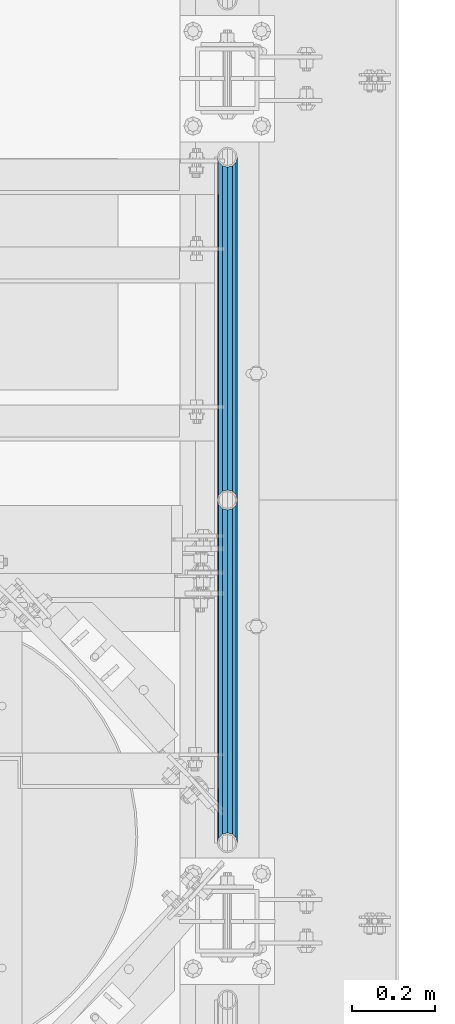
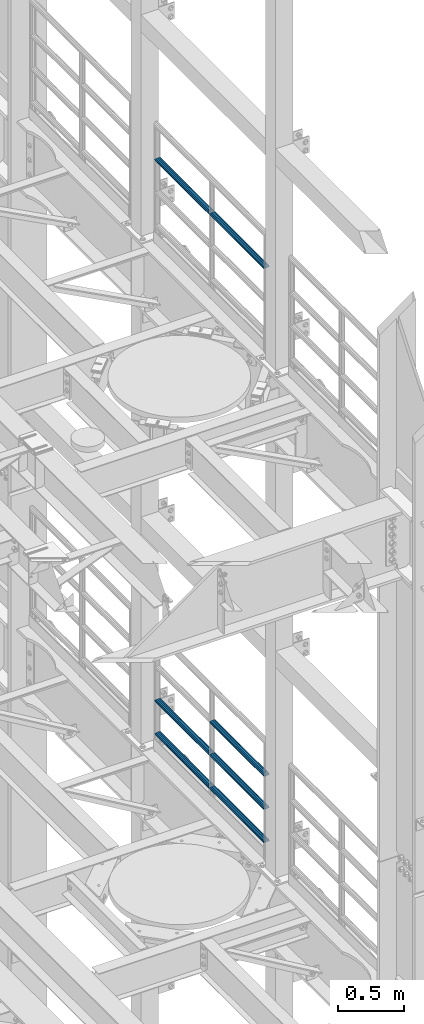
# One storey, part 1279 of 1876: 7 beams, 2 elements without a shape of their own.
"""IFC2X3 building model written with IfcOpenShell, lengths in millimetres."""

from ifc_helpers import new_model, si_unit, frame, origin_with_axes, place, context, subcontext, project, spatial, faceted_brep, material, type_object, element, aggregate, save


model = new_model("IFC2X3")

# Units and contexts
model_context = context("Model", 3, precision=1e-05, world=origin_with_axes())
body_context = subcontext(model_context, "Body", "Model", "MODEL_VIEW")
ifc_project = project(units=[si_unit("LENGTHUNIT", "METRE", prefix="MILLI"), si_unit("AREAUNIT", "SQUARE_METRE"), si_unit("VOLUMEUNIT", "CUBIC_METRE"), si_unit("MASSUNIT", "GRAM", prefix="KILO"), si_unit("TIMEUNIT", "SECOND"), si_unit("PLANEANGLEUNIT", "RADIAN"), si_unit("SOLIDANGLEUNIT", "STERADIAN"), si_unit("THERMODYNAMICTEMPERATUREUNIT", "DEGREE_CELSIUS"), si_unit("LUMINOUSINTENSITYUNIT", "LUMEN")], contexts=[model_context])

# Site, building, storey
site_placement = place(None, origin_with_axes())
site = spatial("IfcSite", under=ifc_project, at=site_placement, CompositionType="ELEMENT")
building_placement = place(site_placement, origin_with_axes())
building = spatial("IfcBuilding", under=site, at=building_placement, Name="Undefined", CompositionType="ELEMENT")
storey_placement = place(building_placement, origin_with_axes())
storey = spatial("IfcBuildingStorey", under=building, at=storey_placement, Name="Undefined", CompositionType="ELEMENT", Elevation=0.0)

# Assembly, beams
assembly_1_placement = place(storey_placement, origin_with_axes())
assembly_1 = element("IfcElementAssembly", 1, at=assembly_1_placement, inside=storey, Name="RAIL", AssemblyPlace="NOTDEFINED", PredefinedType="RIGID_FRAME")
ifc_material = material()
beam_type = type_object("IfcBeamType", Name="PIPE1-1/2SCH40", PredefinedType="NOTDEFINED")
beam_1_placement = place(assembly_1_placement, frame((7620.0, 3745.23, 18754.725), z_axis=(0.0, 0.0, -1.0), x_axis=(0.0, 1.0, 0.0)))
beam_1 = element("IfcBeam", 2, at=beam_1_placement, type_object=beam_type, material=ifc_material, Name="RAIL", ObjectType="PIPE1-1/2SCH40", context=body_context, shape_type="Brep", body=[
    faceted_brep([(0.0, 24.1299999999992, 0.0), (12.0650000000064, 20.8971929933177, -12.0649999999987), (12.0650000000064, 20.8971929933177, 12.0649999999987), (12.0650000000064, -20.8971929933177, 12.0649999999987), (12.0650000000064, -20.8971929933177, -12.0649999999987), (0.0, -24.1299999999992, 0.0), (20.8971929933249, -12.0650000000005, 20.8971929933177), (20.8971929933249, -12.0650000000005, 15.8661214311796), (15.2545715621445, -17.7076214311801, 10.2235000000001), (12.5151929933249, -20.4470000000001, 0.0), (15.2545715621445, -17.7076214311801, -10.2235000000001), (20.8971929933249, -12.0650000000005, -15.8661214311796), (20.8971929933249, -12.0650000000005, -20.8971929933177), (24.1300000000063, 0.0, -20.4470000000001), (24.1300000000063, 0.0, -24.130000000001), (21.3906214311868, -10.2235000000001, -17.7076214311819), (21.3906214311868, 10.2235000000001, -17.7076214311819), (20.8971929933249, 12.0650000000005, -15.8661214311796), (20.8971929933249, 12.0650000000005, -20.8971929933177), (15.2545715621445, 17.7076214311801, -10.2235000000001), (12.5151929933249, 20.4470000000001, 0.0), (15.2545715621445, 17.7076214311801, 10.2235000000001), (20.8971929933249, 12.0650000000005, 15.8661214311796), (20.8971929933249, 12.0650000000005, 20.8971929933177), (21.3906214311868, 10.2235000000001, 17.7076214311819), (24.1300000000064, 0.0, 20.4470000000001), (24.1300000000064, 0.0, 24.130000000001), (21.3906214311868, -10.2235000000001, 17.7076214311819), (826.77, 24.1300000000001, 0.0), (814.705, 20.8971929933186, -12.0649999999987), (805.872807006681, 12.0649999999996, -20.8971929933177), (826.77, -24.1300000000001, 0.0), (814.705, -20.8971929933186, -12.0649999999987), (814.705, -20.8971929933186, 12.0649999999987), (805.872807006681, -12.0649999999996, 20.8971929933177), (805.872807006681, -12.0649999999996, -20.8971929933177), (802.640000000001, 0.0, -24.130000000001), (805.379378568819, 10.2235000000001, -17.7076214311819), (802.640000000001, 0.0, -20.4470000000001), (805.872807006683, 12.0649999999996, -15.8661214311796), (805.872807006683, -12.0649999999996, -15.8661214311796), (805.379378568819, -10.2235000000001, -17.7076214311819), (811.515428437862, -17.7076214311801, -10.2235000000001), (814.254807006682, -20.4470000000001, 0.0), (811.515428437862, -17.7076214311801, 10.2235000000001), (805.872807006683, -12.0649999999996, 15.8661214311796), (805.379378568819, -10.2235000000001, 17.7076214311819), (802.640000000001, 0.0, 20.4470000000001), (802.640000000001, 0.0, 24.130000000001), (805.872807006681, 12.0649999999996, 20.8971929933177), (814.705, 20.8971929933186, 12.0649999999987), (805.872807006683, 12.0649999999996, 15.8661214311796), (811.515428437862, 17.7076214311801, 10.2235000000001), (814.254807006682, 20.4470000000001, 0.0), (811.515428437862, 17.7076214311801, -10.2235000000001), (805.379378568819, 10.2235000000001, 17.7076214311819)], [[[0, 1, 2]], [[3, 4, 5]], [[6, 7, 8, 9, 10, 11, 12, 4, 3]], [[13, 14, 12, 11, 15]], [[16, 17, 18, 14, 13]], [[2, 1, 18, 17, 19, 20, 21, 22, 23]], [[23, 22, 24, 25, 26]], [[26, 25, 27, 7, 6]], [[1, 0, 28, 29]], [[18, 1, 29, 30]], [[31, 32, 33]], [[6, 3, 33, 34]], [[3, 5, 31, 33]], [[5, 4, 32, 31]], [[4, 12, 35, 32]], [[12, 14, 36, 35]], [[14, 18, 30, 36]], [[37, 38, 36, 30, 39]], [[40, 35, 36, 38, 41]], [[33, 32, 35, 40, 42, 43, 44, 45, 34]], [[34, 45, 46, 47, 48]], [[26, 6, 34, 48]], [[2, 23, 49, 50]], [[23, 26, 48, 49]], [[0, 2, 50, 28]], [[28, 50, 29]], [[49, 51, 52, 53, 54, 39, 30, 29, 50]], [[48, 47, 55, 51, 49]], [[25, 24, 55, 47]], [[55, 24, 22, 21, 52, 51]], [[21, 20, 53, 52]], [[20, 19, 54, 53]], [[19, 17, 16, 37, 39, 54]], [[16, 13, 38, 37]], [[13, 15, 41, 38]], [[41, 15, 11, 10, 42, 40]], [[10, 9, 43, 42]], [[9, 8, 44, 43]], [[8, 7, 27, 46, 45, 44]], [[27, 25, 47, 46]]]),
])
beam_2_placement = place(assembly_1_placement, frame((7620.0, 4572.0, 18754.725), z_axis=(0.0, 0.0, -1.0), x_axis=(0.0, 1.0, 0.0)))
beam_2 = element("IfcBeam", 3, at=beam_2_placement, type_object=beam_type, material=ifc_material, Name="RAIL", ObjectType="PIPE1-1/2SCH40", context=body_context, shape_type="Brep", body=[
    faceted_brep([(0.0, 24.1299999999992, 0.0), (12.0650000000064, 20.8971929933177, -12.0649999999987), (12.0650000000064, 20.8971929933177, 12.0649999999987), (12.0650000000064, -20.8971929933177, 12.0649999999987), (12.0650000000064, -20.8971929933177, -12.0649999999987), (0.0, -24.1299999999992, 0.0), (20.8971929933249, -12.0650000000005, 20.8971929933177), (20.8971929933249, -12.0650000000005, 15.8661214311796), (15.2545715621445, -17.7076214311801, 10.2235000000001), (12.5151929933249, -20.4470000000001, 0.0), (15.2545715621445, -17.7076214311801, -10.2235000000001), (20.8971929933249, -12.0650000000005, -15.8661214311796), (20.8971929933249, -12.0650000000005, -20.8971929933177), (24.1300000000063, 0.0, -20.4470000000001), (24.1300000000063, 0.0, -24.130000000001), (21.3906214311868, -10.2235000000001, -17.7076214311819), (21.3906214311868, 10.2235000000001, -17.7076214311819), (20.8971929933249, 12.0650000000005, -15.8661214311796), (20.8971929933249, 12.0650000000005, -20.8971929933177), (15.2545715621445, 17.7076214311801, -10.2235000000001), (12.5151929933249, 20.4470000000001, 0.0), (15.2545715621445, 17.7076214311801, 10.2235000000001), (20.8971929933249, 12.0650000000005, 15.8661214311796), (20.8971929933249, 12.0650000000005, 20.8971929933177), (21.3906214311868, 10.2235000000001, 17.7076214311819), (24.1300000000064, 0.0, 20.4470000000001), (24.1300000000064, 0.0, 24.130000000001), (21.3906214311868, -10.2235000000001, 17.7076214311819), (826.77, 24.1300000000001, 0.0), (814.705, 20.8971929933186, -12.0649999999987), (805.872807006681, 12.0649999999996, -20.8971929933177), (826.77, -24.1300000000001, 0.0), (814.705, -20.8971929933186, -12.0649999999987), (814.705, -20.8971929933186, 12.0649999999987), (805.872807006681, -12.0649999999996, 20.8971929933177), (805.872807006681, -12.0649999999996, -20.8971929933177), (802.640000000001, 0.0, -24.130000000001), (805.379378568819, 10.2235000000001, -17.7076214311819), (802.640000000001, 0.0, -20.4470000000001), (805.872807006683, 12.0649999999996, -15.8661214311796), (805.872807006683, -12.0649999999996, -15.8661214311796), (805.379378568819, -10.2235000000001, -17.7076214311819), (811.515428437862, -17.7076214311801, -10.2235000000001), (814.254807006682, -20.4470000000001, 0.0), (811.515428437862, -17.7076214311801, 10.2235000000001), (805.872807006683, -12.0649999999996, 15.8661214311796), (805.379378568819, -10.2235000000001, 17.7076214311819), (802.640000000001, 0.0, 20.4470000000001), (802.640000000001, 0.0, 24.130000000001), (805.872807006681, 12.0649999999996, 20.8971929933177), (814.705, 20.8971929933186, 12.0649999999987), (805.872807006683, 12.0649999999996, 15.8661214311796), (811.515428437862, 17.7076214311801, 10.2235000000001), (814.254807006682, 20.4470000000001, 0.0), (811.515428437862, 17.7076214311801, -10.2235000000001), (805.379378568819, 10.2235000000001, 17.7076214311819)], [[[0, 1, 2]], [[3, 4, 5]], [[6, 7, 8, 9, 10, 11, 12, 4, 3]], [[13, 14, 12, 11, 15]], [[16, 17, 18, 14, 13]], [[2, 1, 18, 17, 19, 20, 21, 22, 23]], [[23, 22, 24, 25, 26]], [[26, 25, 27, 7, 6]], [[1, 0, 28, 29]], [[18, 1, 29, 30]], [[31, 32, 33]], [[6, 3, 33, 34]], [[3, 5, 31, 33]], [[5, 4, 32, 31]], [[4, 12, 35, 32]], [[12, 14, 36, 35]], [[14, 18, 30, 36]], [[37, 38, 36, 30, 39]], [[40, 35, 36, 38, 41]], [[33, 32, 35, 40, 42, 43, 44, 45, 34]], [[34, 45, 46, 47, 48]], [[26, 6, 34, 48]], [[2, 23, 49, 50]], [[23, 26, 48, 49]], [[0, 2, 50, 28]], [[28, 50, 29]], [[49, 51, 52, 53, 54, 39, 30, 29, 50]], [[48, 47, 55, 51, 49]], [[25, 24, 55, 47]], [[55, 24, 22, 21, 52, 51]], [[21, 20, 53, 52]], [[20, 19, 54, 53]], [[19, 17, 16, 37, 39, 54]], [[16, 13, 38, 37]], [[13, 15, 41, 38]], [[41, 15, 11, 10, 42, 40]], [[10, 9, 43, 42]], [[9, 8, 44, 43]], [[8, 7, 27, 46, 45, 44]], [[27, 25, 47, 46]]]),
])
aggregate(assembly_1, [beam_1, beam_2])

assembly_2_placement = place(storey_placement, origin_with_axes())
assembly_2 = element("IfcElementAssembly", 4, at=assembly_2_placement, inside=storey, Name="RAIL", AssemblyPlace="NOTDEFINED", PredefinedType="RIGID_FRAME")
beam_3_placement = place(assembly_2_placement, frame((7620.0, 4572.0, 13471.525), z_axis=(0.0, 0.0, 1.0), x_axis=(0.0, -1.0, 0.0)))
beam_3 = element("IfcBeam", 5, at=beam_3_placement, type_object=beam_type, material=ifc_material, Name="RAIL", ObjectType="PIPE1-1/2SCH40", context=body_context, shape_type="Brep", body=[
    faceted_brep([(805.872807006681, -12.0649999999996, 20.8971929933177), (805.872807006683, -12.0649999999996, 15.8661214311796), (805.379378568819, -10.2235000000001, 17.7076214311819), (802.640000000001, 0.0, 20.4470000000001), (802.640000000001, 0.0, 24.130000000001), (805.379378568819, 10.2235000000001, 17.7076214311819), (805.872807006683, 12.0649999999996, 15.8661214311796), (805.872807006681, 12.0649999999996, 20.8971929933177), (826.77, 24.1300000000001, 0.0), (814.705, 20.8971929933186, 12.0649999999987), (814.705, 20.8971929933186, -12.0649999999987), (811.515428437862, 17.7076214311801, 10.2235000000001), (814.254807006682, 20.4470000000001, 0.0), (811.515428437862, 17.7076214311801, -10.2235000000001), (805.872807006683, 12.0649999999996, -15.8661214311796), (805.872807006681, 12.0649999999996, -20.8971929933177), (805.379378568819, 10.2235000000001, -17.7076214311819), (802.640000000001, 0.0, -20.4470000000001), (802.640000000001, 0.0, -24.130000000001), (805.872807006683, -12.0649999999996, -15.8661214311796), (805.872807006681, -12.0649999999996, -20.8971929933177), (805.379378568819, -10.2235000000001, -17.7076214311819), (826.77, -24.1300000000001, 0.0), (814.705, -20.8971929933186, -12.0649999999987), (814.705, -20.8971929933186, 12.0649999999987), (811.515428437862, -17.7076214311801, -10.2235000000001), (814.254807006682, -20.4470000000001, 0.0), (811.515428437862, -17.7076214311801, 10.2235000000001), (12.0650000000064, -20.8971929933177, -12.0649999999987), (20.8971929933249, -12.0650000000005, -20.8971929933177), (0.0, 24.1299999999992, 0.0), (12.0650000000064, 20.8971929933177, -12.0649999999987), (12.0650000000064, 20.8971929933177, 12.0649999999987), (20.8971929933249, 12.0650000000005, 20.8971929933177), (24.1300000000064, 0.0, 24.130000000001), (20.8971929933249, 12.0650000000005, -20.8971929933177), (24.1300000000063, 0.0, -24.130000000001), (24.1300000000063, 0.0, -20.4470000000001), (20.8971929933249, -12.0650000000005, -15.8661214311796), (21.3906214311868, -10.2235000000001, -17.7076214311819), (21.3906214311868, 10.2235000000001, -17.7076214311819), (20.8971929933249, 12.0650000000005, -15.8661214311796), (15.2545715621445, 17.7076214311801, -10.2235000000001), (12.5151929933249, 20.4470000000001, 0.0), (15.2545715621445, 17.7076214311801, 10.2235000000001), (20.8971929933249, 12.0650000000005, 15.8661214311796), (21.3906214311868, 10.2235000000001, 17.7076214311819), (24.1300000000064, 0.0, 20.4470000000001), (21.3906214311868, -10.2235000000001, 17.7076214311819), (20.8971929933249, -12.0650000000005, 15.8661214311796), (20.8971929933249, -12.0650000000005, 20.8971929933177), (12.0650000000064, -20.8971929933177, 12.0649999999987), (0.0, -24.1299999999992, 0.0), (15.2545715621445, -17.7076214311801, 10.2235000000001), (12.5151929933249, -20.4470000000001, 0.0), (15.2545715621445, -17.7076214311801, -10.2235000000001)], [[[0, 1, 2, 3, 4]], [[4, 3, 5, 6, 7]], [[8, 9, 10]], [[7, 6, 11, 12, 13, 14, 15, 10, 9]], [[16, 17, 18, 15, 14]], [[19, 20, 18, 17, 21]], [[22, 23, 24]], [[24, 23, 20, 19, 25, 26, 27, 1, 0]], [[28, 29, 20, 23]], [[30, 31, 32]], [[33, 34, 4, 7]], [[32, 33, 7, 9]], [[30, 32, 9, 8]], [[31, 30, 8, 10]], [[35, 31, 10, 15]], [[36, 35, 15, 18]], [[29, 36, 18, 20]], [[37, 36, 29, 38, 39]], [[40, 41, 35, 36, 37]], [[32, 31, 35, 41, 42, 43, 44, 45, 33]], [[33, 45, 46, 47, 34]], [[34, 47, 48, 49, 50]], [[34, 50, 0, 4]], [[50, 51, 24, 0]], [[51, 52, 22, 24]], [[52, 28, 23, 22]], [[51, 28, 52]], [[50, 49, 53, 54, 55, 38, 29, 28, 51]], [[55, 54, 26, 25]], [[21, 39, 38, 55, 25, 19]], [[37, 39, 21, 17]], [[40, 37, 17, 16]], [[42, 41, 40, 16, 14, 13]], [[43, 42, 13, 12]], [[44, 43, 12, 11]], [[5, 46, 45, 44, 11, 6]], [[47, 46, 5, 3]], [[48, 47, 3, 2]], [[53, 49, 48, 2, 1, 27]], [[54, 53, 27, 26]]]),
])
beam_4_placement = place(assembly_2_placement, frame((7620.0, 5398.77, 13471.525), z_axis=(0.0, 0.0, 1.0), x_axis=(0.0, -1.0, 0.0)))
beam_4 = element("IfcBeam", 6, at=beam_4_placement, type_object=beam_type, material=ifc_material, Name="RAIL", ObjectType="PIPE1-1/2SCH40", context=body_context, shape_type="Brep", body=[
    faceted_brep([(805.872807006681, -12.0649999999996, 20.8971929933177), (805.872807006683, -12.0649999999996, 15.8661214311796), (805.379378568819, -10.2235000000001, 17.7076214311819), (802.640000000001, 0.0, 20.4470000000001), (802.640000000001, 0.0, 24.130000000001), (805.379378568819, 10.2235000000001, 17.7076214311819), (805.872807006683, 12.0649999999996, 15.8661214311796), (805.872807006681, 12.0649999999996, 20.8971929933177), (826.77, 24.1300000000001, 0.0), (814.705, 20.8971929933186, 12.0649999999987), (814.705, 20.8971929933186, -12.0649999999987), (811.515428437862, 17.7076214311801, 10.2235000000001), (814.254807006682, 20.4470000000001, 0.0), (811.515428437862, 17.7076214311801, -10.2235000000001), (805.872807006683, 12.0649999999996, -15.8661214311796), (805.872807006681, 12.0649999999996, -20.8971929933177), (805.379378568819, 10.2235000000001, -17.7076214311819), (802.640000000001, 0.0, -20.4470000000001), (802.640000000001, 0.0, -24.130000000001), (805.872807006683, -12.0649999999996, -15.8661214311796), (805.872807006681, -12.0649999999996, -20.8971929933177), (805.379378568819, -10.2235000000001, -17.7076214311819), (826.77, -24.1300000000001, 0.0), (814.705, -20.8971929933186, -12.0649999999987), (814.705, -20.8971929933186, 12.0649999999987), (811.515428437862, -17.7076214311801, -10.2235000000001), (814.254807006682, -20.4470000000001, 0.0), (811.515428437862, -17.7076214311801, 10.2235000000001), (12.0650000000064, -20.8971929933177, -12.0649999999987), (20.8971929933249, -12.0650000000005, -20.8971929933177), (0.0, 24.1299999999992, 0.0), (12.0650000000064, 20.8971929933177, -12.0649999999987), (12.0650000000064, 20.8971929933177, 12.0649999999987), (20.8971929933249, 12.0650000000005, 20.8971929933177), (24.1300000000064, 0.0, 24.130000000001), (20.8971929933249, 12.0650000000005, -20.8971929933177), (24.1300000000063, 0.0, -24.130000000001), (24.1300000000063, 0.0, -20.4470000000001), (20.8971929933249, -12.0650000000005, -15.8661214311796), (21.3906214311868, -10.2235000000001, -17.7076214311819), (21.3906214311868, 10.2235000000001, -17.7076214311819), (20.8971929933249, 12.0650000000005, -15.8661214311796), (15.2545715621445, 17.7076214311801, -10.2235000000001), (12.5151929933249, 20.4470000000001, 0.0), (15.2545715621445, 17.7076214311801, 10.2235000000001), (20.8971929933249, 12.0650000000005, 15.8661214311796), (21.3906214311868, 10.2235000000001, 17.7076214311819), (24.1300000000064, 0.0, 20.4470000000001), (21.3906214311868, -10.2235000000001, 17.7076214311819), (20.8971929933249, -12.0650000000005, 15.8661214311796), (20.8971929933249, -12.0650000000005, 20.8971929933177), (12.0650000000064, -20.8971929933177, 12.0649999999987), (0.0, -24.1299999999992, 0.0), (15.2545715621445, -17.7076214311801, 10.2235000000001), (12.5151929933249, -20.4470000000001, 0.0), (15.2545715621445, -17.7076214311801, -10.2235000000001)], [[[0, 1, 2, 3, 4]], [[4, 3, 5, 6, 7]], [[8, 9, 10]], [[7, 6, 11, 12, 13, 14, 15, 10, 9]], [[16, 17, 18, 15, 14]], [[19, 20, 18, 17, 21]], [[22, 23, 24]], [[24, 23, 20, 19, 25, 26, 27, 1, 0]], [[28, 29, 20, 23]], [[30, 31, 32]], [[33, 34, 4, 7]], [[32, 33, 7, 9]], [[30, 32, 9, 8]], [[31, 30, 8, 10]], [[35, 31, 10, 15]], [[36, 35, 15, 18]], [[29, 36, 18, 20]], [[37, 36, 29, 38, 39]], [[40, 41, 35, 36, 37]], [[32, 31, 35, 41, 42, 43, 44, 45, 33]], [[33, 45, 46, 47, 34]], [[34, 47, 48, 49, 50]], [[34, 50, 0, 4]], [[50, 51, 24, 0]], [[51, 52, 22, 24]], [[52, 28, 23, 22]], [[51, 28, 52]], [[50, 49, 53, 54, 55, 38, 29, 28, 51]], [[55, 54, 26, 25]], [[21, 39, 38, 55, 25, 19]], [[37, 39, 21, 17]], [[40, 37, 17, 16]], [[42, 41, 40, 16, 14, 13]], [[43, 42, 13, 12]], [[44, 43, 12, 11]], [[5, 46, 45, 44, 11, 6]], [[47, 46, 5, 3]], [[48, 47, 3, 2]], [[53, 49, 48, 2, 1, 27]], [[54, 53, 27, 26]]]),
])
beam_5_placement = place(assembly_2_placement, frame((7620.0, 3745.23, 13776.325), z_axis=(0.0, 0.0, -1.0), x_axis=(0.0, 1.0, 0.0)))
beam_5 = element("IfcBeam", 7, at=beam_5_placement, type_object=beam_type, material=ifc_material, Name="RAIL", ObjectType="PIPE1-1/2SCH40", context=body_context, shape_type="Brep", body=[
    faceted_brep([(0.0, 24.1299999999992, 0.0), (12.0650000000064, 20.8971929933177, -12.0649999999987), (12.0650000000064, 20.8971929933177, 12.0649999999987), (12.0650000000064, -20.8971929933177, 12.0649999999987), (12.0650000000064, -20.8971929933177, -12.0649999999987), (0.0, -24.1299999999992, 0.0), (20.8971929933249, -12.0650000000005, 20.8971929933177), (20.8971929933249, -12.0650000000005, 15.8661214311796), (15.2545715621445, -17.7076214311801, 10.2235000000001), (12.5151929933249, -20.4470000000001, 0.0), (15.2545715621445, -17.7076214311801, -10.2235000000001), (20.8971929933249, -12.0650000000005, -15.8661214311796), (20.8971929933249, -12.0650000000005, -20.8971929933177), (24.1300000000063, 0.0, -20.4470000000001), (24.1300000000063, 0.0, -24.130000000001), (21.3906214311868, -10.2235000000001, -17.7076214311819), (21.3906214311868, 10.2235000000001, -17.7076214311819), (20.8971929933249, 12.0650000000005, -15.8661214311796), (20.8971929933249, 12.0650000000005, -20.8971929933177), (15.2545715621445, 17.7076214311801, -10.2235000000001), (12.5151929933249, 20.4470000000001, 0.0), (15.2545715621445, 17.7076214311801, 10.2235000000001), (20.8971929933249, 12.0650000000005, 15.8661214311796), (20.8971929933249, 12.0650000000005, 20.8971929933177), (21.3906214311868, 10.2235000000001, 17.7076214311819), (24.1300000000064, 0.0, 20.4470000000001), (24.1300000000064, 0.0, 24.130000000001), (21.3906214311868, -10.2235000000001, 17.7076214311819), (826.77, 24.1300000000001, 0.0), (814.705, 20.8971929933186, -12.0649999999987), (805.872807006681, 12.0649999999996, -20.8971929933177), (826.77, -24.1300000000001, 0.0), (814.705, -20.8971929933186, -12.0649999999987), (814.705, -20.8971929933186, 12.0649999999987), (805.872807006681, -12.0649999999996, 20.8971929933177), (805.872807006681, -12.0649999999996, -20.8971929933177), (802.640000000001, 0.0, -24.130000000001), (805.379378568819, 10.2235000000001, -17.7076214311819), (802.640000000001, 0.0, -20.4470000000001), (805.872807006683, 12.0649999999996, -15.8661214311796), (805.872807006683, -12.0649999999996, -15.8661214311796), (805.379378568819, -10.2235000000001, -17.7076214311819), (811.515428437862, -17.7076214311801, -10.2235000000001), (814.254807006682, -20.4470000000001, 0.0), (811.515428437862, -17.7076214311801, 10.2235000000001), (805.872807006683, -12.0649999999996, 15.8661214311796), (805.379378568819, -10.2235000000001, 17.7076214311819), (802.640000000001, 0.0, 20.4470000000001), (802.640000000001, 0.0, 24.130000000001), (805.872807006681, 12.0649999999996, 20.8971929933177), (814.705, 20.8971929933186, 12.0649999999987), (805.872807006683, 12.0649999999996, 15.8661214311796), (811.515428437862, 17.7076214311801, 10.2235000000001), (814.254807006682, 20.4470000000001, 0.0), (811.515428437862, 17.7076214311801, -10.2235000000001), (805.379378568819, 10.2235000000001, 17.7076214311819)], [[[0, 1, 2]], [[3, 4, 5]], [[6, 7, 8, 9, 10, 11, 12, 4, 3]], [[13, 14, 12, 11, 15]], [[16, 17, 18, 14, 13]], [[2, 1, 18, 17, 19, 20, 21, 22, 23]], [[23, 22, 24, 25, 26]], [[26, 25, 27, 7, 6]], [[1, 0, 28, 29]], [[18, 1, 29, 30]], [[31, 32, 33]], [[6, 3, 33, 34]], [[3, 5, 31, 33]], [[5, 4, 32, 31]], [[4, 12, 35, 32]], [[12, 14, 36, 35]], [[14, 18, 30, 36]], [[37, 38, 36, 30, 39]], [[40, 35, 36, 38, 41]], [[33, 32, 35, 40, 42, 43, 44, 45, 34]], [[34, 45, 46, 47, 48]], [[26, 6, 34, 48]], [[2, 23, 49, 50]], [[23, 26, 48, 49]], [[0, 2, 50, 28]], [[28, 50, 29]], [[49, 51, 52, 53, 54, 39, 30, 29, 50]], [[48, 47, 55, 51, 49]], [[25, 24, 55, 47]], [[55, 24, 22, 21, 52, 51]], [[21, 20, 53, 52]], [[20, 19, 54, 53]], [[19, 17, 16, 37, 39, 54]], [[16, 13, 38, 37]], [[13, 15, 41, 38]], [[41, 15, 11, 10, 42, 40]], [[10, 9, 43, 42]], [[9, 8, 44, 43]], [[8, 7, 27, 46, 45, 44]], [[27, 25, 47, 46]]]),
])
beam_6_placement = place(assembly_2_placement, frame((7620.0, 4572.0, 13776.325), z_axis=(0.0, 0.0, -1.0), x_axis=(0.0, 1.0, 0.0)))
beam_6 = element("IfcBeam", 8, at=beam_6_placement, type_object=beam_type, material=ifc_material, Name="RAIL", ObjectType="PIPE1-1/2SCH40", context=body_context, shape_type="Brep", body=[
    faceted_brep([(0.0, 24.1299999999992, 0.0), (12.0650000000064, 20.8971929933177, -12.0649999999987), (12.0650000000064, 20.8971929933177, 12.0649999999987), (12.0650000000064, -20.8971929933177, 12.0649999999987), (12.0650000000064, -20.8971929933177, -12.0649999999987), (0.0, -24.1299999999992, 0.0), (20.8971929933249, -12.0650000000005, 20.8971929933177), (20.8971929933249, -12.0650000000005, 15.8661214311796), (15.2545715621445, -17.7076214311801, 10.2235000000001), (12.5151929933249, -20.4470000000001, 0.0), (15.2545715621445, -17.7076214311801, -10.2235000000001), (20.8971929933249, -12.0650000000005, -15.8661214311796), (20.8971929933249, -12.0650000000005, -20.8971929933177), (24.1300000000063, 0.0, -20.4470000000001), (24.1300000000063, 0.0, -24.130000000001), (21.3906214311868, -10.2235000000001, -17.7076214311819), (21.3906214311868, 10.2235000000001, -17.7076214311819), (20.8971929933249, 12.0650000000005, -15.8661214311796), (20.8971929933249, 12.0650000000005, -20.8971929933177), (15.2545715621445, 17.7076214311801, -10.2235000000001), (12.5151929933249, 20.4470000000001, 0.0), (15.2545715621445, 17.7076214311801, 10.2235000000001), (20.8971929933249, 12.0650000000005, 15.8661214311796), (20.8971929933249, 12.0650000000005, 20.8971929933177), (21.3906214311868, 10.2235000000001, 17.7076214311819), (24.1300000000064, 0.0, 20.4470000000001), (24.1300000000064, 0.0, 24.130000000001), (21.3906214311868, -10.2235000000001, 17.7076214311819), (826.77, 24.1300000000001, 0.0), (814.705, 20.8971929933186, -12.0649999999987), (805.872807006681, 12.0649999999996, -20.8971929933177), (826.77, -24.1300000000001, 0.0), (814.705, -20.8971929933186, -12.0649999999987), (814.705, -20.8971929933186, 12.0649999999987), (805.872807006681, -12.0649999999996, 20.8971929933177), (805.872807006681, -12.0649999999996, -20.8971929933177), (802.640000000001, 0.0, -24.130000000001), (805.379378568819, 10.2235000000001, -17.7076214311819), (802.640000000001, 0.0, -20.4470000000001), (805.872807006683, 12.0649999999996, -15.8661214311796), (805.872807006683, -12.0649999999996, -15.8661214311796), (805.379378568819, -10.2235000000001, -17.7076214311819), (811.515428437862, -17.7076214311801, -10.2235000000001), (814.254807006682, -20.4470000000001, 0.0), (811.515428437862, -17.7076214311801, 10.2235000000001), (805.872807006683, -12.0649999999996, 15.8661214311796), (805.379378568819, -10.2235000000001, 17.7076214311819), (802.640000000001, 0.0, 20.4470000000001), (802.640000000001, 0.0, 24.130000000001), (805.872807006681, 12.0649999999996, 20.8971929933177), (814.705, 20.8971929933186, 12.0649999999987), (805.872807006683, 12.0649999999996, 15.8661214311796), (811.515428437862, 17.7076214311801, 10.2235000000001), (814.254807006682, 20.4470000000001, 0.0), (811.515428437862, 17.7076214311801, -10.2235000000001), (805.379378568819, 10.2235000000001, 17.7076214311819)], [[[0, 1, 2]], [[3, 4, 5]], [[6, 7, 8, 9, 10, 11, 12, 4, 3]], [[13, 14, 12, 11, 15]], [[16, 17, 18, 14, 13]], [[2, 1, 18, 17, 19, 20, 21, 22, 23]], [[23, 22, 24, 25, 26]], [[26, 25, 27, 7, 6]], [[1, 0, 28, 29]], [[18, 1, 29, 30]], [[31, 32, 33]], [[6, 3, 33, 34]], [[3, 5, 31, 33]], [[5, 4, 32, 31]], [[4, 12, 35, 32]], [[12, 14, 36, 35]], [[14, 18, 30, 36]], [[37, 38, 36, 30, 39]], [[40, 35, 36, 38, 41]], [[33, 32, 35, 40, 42, 43, 44, 45, 34]], [[34, 45, 46, 47, 48]], [[26, 6, 34, 48]], [[2, 23, 49, 50]], [[23, 26, 48, 49]], [[0, 2, 50, 28]], [[28, 50, 29]], [[49, 51, 52, 53, 54, 39, 30, 29, 50]], [[48, 47, 55, 51, 49]], [[25, 24, 55, 47]], [[55, 24, 22, 21, 52, 51]], [[21, 20, 53, 52]], [[20, 19, 54, 53]], [[19, 17, 16, 37, 39, 54]], [[16, 13, 38, 37]], [[13, 15, 41, 38]], [[41, 15, 11, 10, 42, 40]], [[10, 9, 43, 42]], [[9, 8, 44, 43]], [[8, 7, 27, 46, 45, 44]], [[27, 25, 47, 46]]]),
])
beam_7_placement = place(assembly_2_placement, frame((7620.0, 3745.23, 14081.125), z_axis=(0.0, 0.0, -1.0), x_axis=(0.0, 1.0, 0.0)))
beam_7 = element("IfcBeam", 9, at=beam_7_placement, type_object=beam_type, material=ifc_material, Name="RAIL", ObjectType="PIPE1-1/2SCH40", context=body_context, shape_type="Brep", body=[
    faceted_brep([(0.0, 24.1299999999992, 0.0), (12.0650000000064, 20.8971929933177, -12.0649999999987), (12.0650000000064, 20.8971929933177, 12.0649999999987), (12.0650000000064, -20.8971929933177, 12.0649999999987), (12.0650000000064, -20.8971929933177, -12.0649999999987), (0.0, -24.1299999999992, 0.0), (20.8971929933249, -12.0650000000005, 20.8971929933177), (20.8971929933249, -12.0650000000005, 15.8661214311796), (15.2545715621445, -17.7076214311801, 10.2235000000001), (12.5151929933249, -20.4470000000001, 0.0), (15.2545715621445, -17.7076214311801, -10.2235000000001), (20.8971929933249, -12.0650000000005, -15.8661214311796), (20.8971929933249, -12.0650000000005, -20.8971929933177), (24.1300000000063, 0.0, -20.4470000000001), (24.1300000000063, 0.0, -24.130000000001), (21.3906214311868, -10.2235000000001, -17.7076214311819), (21.3906214311868, 10.2235000000001, -17.7076214311819), (20.8971929933249, 12.0650000000005, -15.8661214311796), (20.8971929933249, 12.0650000000005, -20.8971929933177), (15.2545715621445, 17.7076214311801, -10.2235000000001), (12.5151929933249, 20.4470000000001, 0.0), (15.2545715621445, 17.7076214311801, 10.2235000000001), (20.8971929933249, 12.0650000000005, 15.8661214311796), (20.8971929933249, 12.0650000000005, 20.8971929933177), (21.3906214311868, 10.2235000000001, 17.7076214311819), (24.1300000000064, 0.0, 20.4470000000001), (24.1300000000064, 0.0, 24.130000000001), (21.3906214311868, -10.2235000000001, 17.7076214311819), (826.77, 24.1300000000001, 0.0), (814.705, 20.8971929933186, -12.0649999999987), (805.872807006681, 12.0649999999996, -20.8971929933177), (826.77, -24.1300000000001, 0.0), (814.705, -20.8971929933186, -12.0649999999987), (814.705, -20.8971929933186, 12.0649999999987), (805.872807006681, -12.0649999999996, 20.8971929933177), (805.872807006681, -12.0649999999996, -20.8971929933177), (802.640000000001, 0.0, -24.130000000001), (805.379378568819, 10.2235000000001, -17.7076214311819), (802.640000000001, 0.0, -20.4470000000001), (805.872807006683, 12.0649999999996, -15.8661214311796), (805.872807006683, -12.0649999999996, -15.8661214311796), (805.379378568819, -10.2235000000001, -17.7076214311819), (811.515428437862, -17.7076214311801, -10.2235000000001), (814.254807006682, -20.4470000000001, 0.0), (811.515428437862, -17.7076214311801, 10.2235000000001), (805.872807006683, -12.0649999999996, 15.8661214311796), (805.379378568819, -10.2235000000001, 17.7076214311819), (802.640000000001, 0.0, 20.4470000000001), (802.640000000001, 0.0, 24.130000000001), (805.872807006681, 12.0649999999996, 20.8971929933177), (814.705, 20.8971929933186, 12.0649999999987), (805.872807006683, 12.0649999999996, 15.8661214311796), (811.515428437862, 17.7076214311801, 10.2235000000001), (814.254807006682, 20.4470000000001, 0.0), (811.515428437862, 17.7076214311801, -10.2235000000001), (805.379378568819, 10.2235000000001, 17.7076214311819)], [[[0, 1, 2]], [[3, 4, 5]], [[6, 7, 8, 9, 10, 11, 12, 4, 3]], [[13, 14, 12, 11, 15]], [[16, 17, 18, 14, 13]], [[2, 1, 18, 17, 19, 20, 21, 22, 23]], [[23, 22, 24, 25, 26]], [[26, 25, 27, 7, 6]], [[1, 0, 28, 29]], [[18, 1, 29, 30]], [[31, 32, 33]], [[6, 3, 33, 34]], [[3, 5, 31, 33]], [[5, 4, 32, 31]], [[4, 12, 35, 32]], [[12, 14, 36, 35]], [[14, 18, 30, 36]], [[37, 38, 36, 30, 39]], [[40, 35, 36, 38, 41]], [[33, 32, 35, 40, 42, 43, 44, 45, 34]], [[34, 45, 46, 47, 48]], [[26, 6, 34, 48]], [[2, 23, 49, 50]], [[23, 26, 48, 49]], [[0, 2, 50, 28]], [[28, 50, 29]], [[49, 51, 52, 53, 54, 39, 30, 29, 50]], [[48, 47, 55, 51, 49]], [[25, 24, 55, 47]], [[55, 24, 22, 21, 52, 51]], [[21, 20, 53, 52]], [[20, 19, 54, 53]], [[19, 17, 16, 37, 39, 54]], [[16, 13, 38, 37]], [[13, 15, 41, 38]], [[41, 15, 11, 10, 42, 40]], [[10, 9, 43, 42]], [[9, 8, 44, 43]], [[8, 7, 27, 46, 45, 44]], [[27, 25, 47, 46]]]),
])
aggregate(assembly_2, [beam_3, beam_4, beam_5, beam_6, beam_7])

save(model, "model.ifc")
